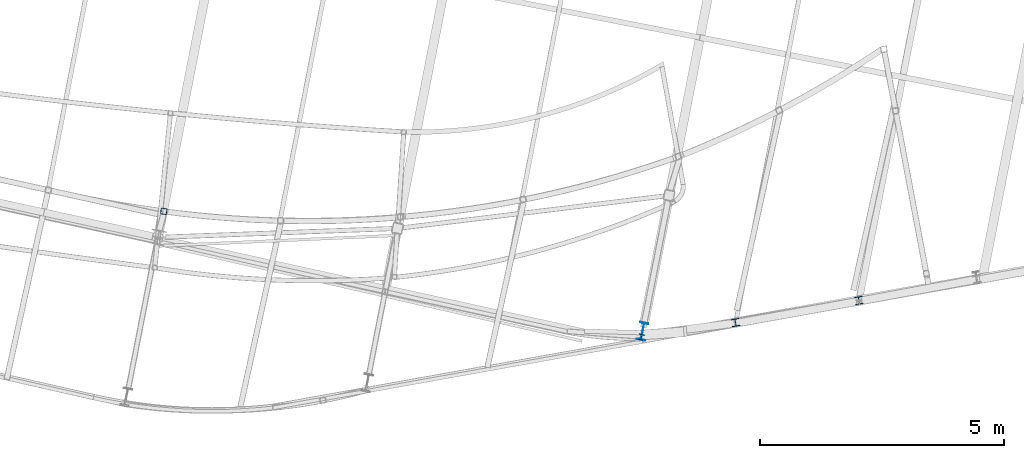
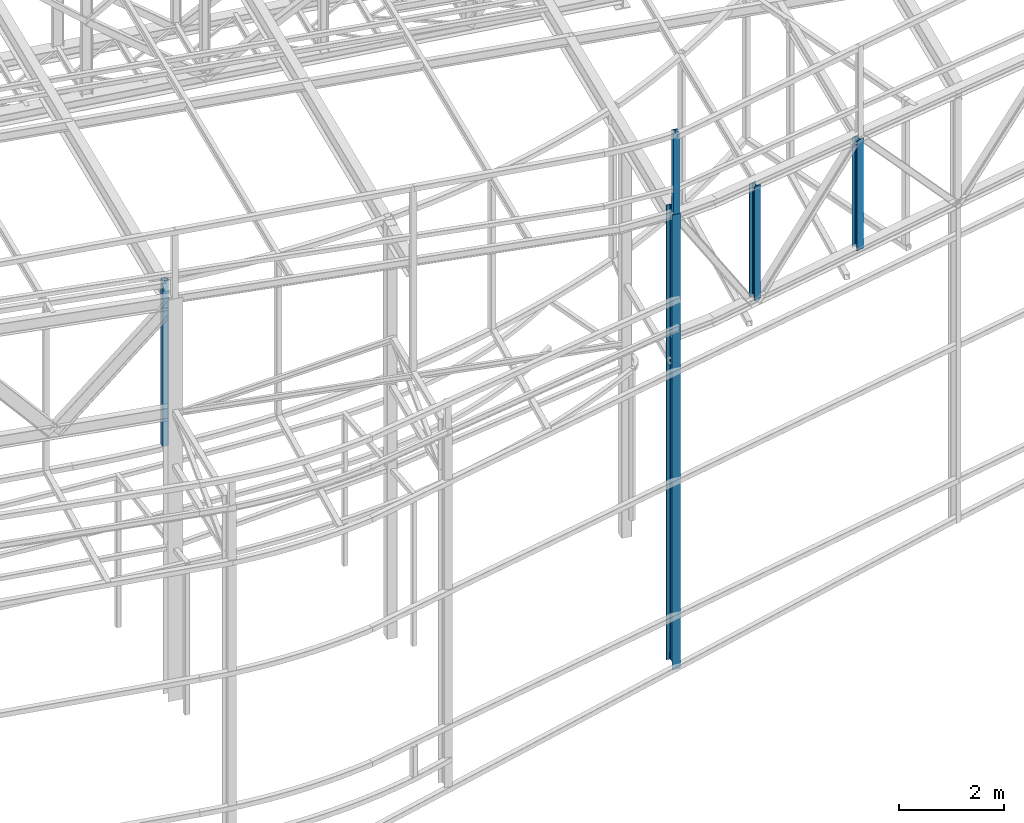
# One storey, part 2 of 215: 5 columns, 5 elements without a shape of their own.
"""IFC2X3 building model written with IfcOpenShell, lengths in millimetres."""

from ifc_helpers import new_model, si_unit, frame, origin_with_axes, origin_2d_with_axis, place, context, subcontext, project, spatial, hollow_rectangle, i_section, extrude, clip, halfspace, material, type_object, element, aggregate, save


model = new_model("IFC2X3")

# Units and contexts
model_context = context("Model", 3, precision=1e-05, world=origin_with_axes())
body_context = subcontext(model_context, "Body", "Model", "MODEL_VIEW")
ifc_project = project(units=[si_unit("LENGTHUNIT", "METRE", prefix="MILLI"), si_unit("AREAUNIT", "SQUARE_METRE"), si_unit("VOLUMEUNIT", "CUBIC_METRE"), si_unit("MASSUNIT", "GRAM", prefix="KILO"), si_unit("TIMEUNIT", "SECOND"), si_unit("PLANEANGLEUNIT", "RADIAN"), si_unit("SOLIDANGLEUNIT", "STERADIAN"), si_unit("THERMODYNAMICTEMPERATUREUNIT", "DEGREE_CELSIUS"), si_unit("LUMINOUSINTENSITYUNIT", "LUMEN")], contexts=[model_context])

# Site, building, storey
site_placement = place(None, origin_with_axes())
site = spatial("IfcSite", under=ifc_project, at=site_placement, CompositionType="ELEMENT")
building_placement = place(site_placement, origin_with_axes())
building = spatial("IfcBuilding", under=site, at=building_placement, Name="Undefined", CompositionType="ELEMENT")
storey_placement = place(building_placement, origin_with_axes())
storey = spatial("IfcBuildingStorey", under=building, at=storey_placement, Name="Undefined", CompositionType="ELEMENT", Elevation=0.0)

# Assembly, column
assembly_1_placement = place(storey_placement, origin_with_axes())
assembly_1 = element("IfcElementAssembly", 1, at=assembly_1_placement, inside=storey, Name="Steel Assembly", AssemblyPlace="NOTDEFINED", PredefinedType="RIGID_FRAME")
ifc_material = material(Name="STEEL/S275JR")
column_type_1 = type_object("IfcColumnType", Name="HEA120", PredefinedType="NOTDEFINED")
column_1_placement = place(assembly_1_placement, frame((84156.8608917441, 1733.75902579516, 14219.9969970389), z_axis=(0.0, 0.0, -1.0), x_axis=(0.191859470081235, 0.981422408415534, 0.0)))
column_1 = element("IfcColumn", 2, at=column_1_placement, type_object=column_type_1, material=ifc_material, ObjectType="HEA120", context=body_context, shape_type="SweptSolid", body=[
    extrude(i_section(OverallWidth=120.0, OverallDepth=114.0, WebThickness=5.0, FlangeThickness=8.0, FilletRadius=12.0, at=origin_2d_with_axis()), frame((-3.63797880709171e-12, -4.94171270849902e-23, 1911.7325076551), z_axis=(0.0, 0.0, -1.0), x_axis=(0.0, 1.0, 0.0)), (0.0, 0.0, 1.0), 1911.7),
])
aggregate(assembly_1, [column_1])

assembly_2_placement = place(storey_placement, origin_with_axes())
assembly_2 = element("IfcElementAssembly", 3, at=assembly_2_placement, inside=storey, Name="Steel Assembly", AssemblyPlace="NOTDEFINED", PredefinedType="RIGID_FRAME")
column_type_2 = type_object("IfcColumnType", PredefinedType="NOTDEFINED")
column_2_placement = place(assembly_2_placement, frame((74381.3873394486, 4309.16223171689, 12623.5706721886), z_axis=(0.0, 0.0, -1.0), x_axis=(-0.129564204956712, -0.991571034668689, 0.0)))
column_2 = element("IfcColumn", 4, at=column_2_placement, type_object=column_type_2, material=ifc_material, Name="LISSE", context=body_context, shape_type="SweptSolid", body=[
    extrude(hollow_rectangle(XDim=120.0, YDim=120.0, WallThickness=5.0, InnerFilletRadius=5.0, OuterFilletRadius=10.0, at=origin_2d_with_axis()), frame((-1.99431687707511e-21, -1.45519152156032e-11, 3857.56986430291), z_axis=(0.0, 0.0, -1.0), x_axis=(0.0, 1.0, 0.0)), (0.0, 0.0, 1.0), 3857.6),
])
aggregate(assembly_2, [column_2])

assembly_3_placement = place(storey_placement, origin_with_axes())
assembly_3 = element("IfcElementAssembly", 5, at=assembly_3_placement, inside=storey, Name="Steel Assembly", AssemblyPlace="NOTDEFINED", PredefinedType="RIGID_FRAME")
column_type_3 = type_object("IfcColumnType", Name="HEA160", PredefinedType="NOTDEFINED")
column_3_placement = place(assembly_3_placement, frame((88608.090874539, 2485.0175407622, 12047.2197031836), z_axis=(0.0, 0.0, -1.0), x_axis=(-0.176543686084636, 0.984292805471852, 0.0)))
column_3 = element("IfcColumn", 6, at=column_3_placement, type_object=column_type_3, material=ifc_material, Name="MONTANT", ObjectType="HEA160", context=body_context, shape_type="SweptSolid", body=[
    extrude(i_section(OverallWidth=160.0, OverallDepth=152.0, WebThickness=6.0, FlangeThickness=9.0, FilletRadius=15.0, at=origin_2d_with_axis()), frame((2.99207072298412e-21, 0.0, 2572.22510302472), z_axis=(0.0, 0.0, -1.0), x_axis=(0.0, 1.0, 0.0)), (0.0, 0.0, 1.0), 2572.2),
])
aggregate(assembly_3, [column_3])

assembly_4_placement = place(storey_placement, origin_with_axes())
assembly_4 = element("IfcElementAssembly", 7, at=assembly_4_placement, inside=storey, Name="Steel Assembly", AssemblyPlace="NOTDEFINED", PredefinedType="RIGID_FRAME")
column_4_placement = place(assembly_4_placement, frame((86082.5757621475, 2032.39887281332, 12121.4863521978), z_axis=(0.0, 0.0, -1.0), x_axis=(-0.174620528064935, 0.984635806366152, 0.0)))
column_4 = element("IfcColumn", 8, at=column_4_placement, type_object=column_type_3, material=ifc_material, Name="MONTANT", ObjectType="HEA160", context=body_context, shape_type="SweptSolid", body=[
    extrude(i_section(OverallWidth=160.0, OverallDepth=152.0, WebThickness=6.0, FlangeThickness=9.0, FilletRadius=15.0, at=origin_2d_with_axis()), frame((-1.81898940163037e-12, 1.45519152633929e-11, 2646.49155245665), z_axis=(0.0, 0.0, -1.0), x_axis=(0.0, 1.0, 0.0)), (0.0, 0.0, 1.0), 2646.5),
])
aggregate(assembly_4, [column_4])

assembly_5_placement = place(storey_placement, origin_with_axes())
assembly_5 = element("IfcElementAssembly", 9, at=assembly_5_placement, inside=storey, Name="Steel Assembly", AssemblyPlace="NOTDEFINED", PredefinedType="RIGID_FRAME")
column_type_4 = type_object("IfcColumnType", Name="IPE360", PredefinedType="NOTDEFINED")
column_5_placement = place(assembly_5_placement, frame((84180.3915322757, 1854.48683107076, 12308.2644892635), z_axis=(0.0, 0.0, -1.0), x_axis=(0.191859470081235, 0.981422408415534, 0.0)))
column_5 = element("IfcColumn", 10, at=column_5_placement, type_object=column_type_4, material=ifc_material, Name="MONTANT", ObjectType="IPE360", context=body_context, shape_type="Clipping", body=[
    clip(extrude(i_section(OverallWidth=170.0, OverallDepth=360.0, WebThickness=8.0, FlangeThickness=12.69999981, FilletRadius=18.0, at=origin_2d_with_axis()), frame((0.0, 0.0, 10605.4484390071), z_axis=(0.0, 0.0, -1.0), x_axis=(0.0, 1.0, 0.0)), (0.0, 0.0, 1.0), 10605.4), halfspace(frame((-232.965654064992, -63.6397149949044, 10605.4255284179), z_axis=(-0.0174219364814336, -0.0411652549673973, -0.999000449405658), x_axis=(0.920920153078385, -0.38975129461502, -9.95698428738485e-10)), True)),
])
aggregate(assembly_5, [column_5])

save(model, "model.ifc")
